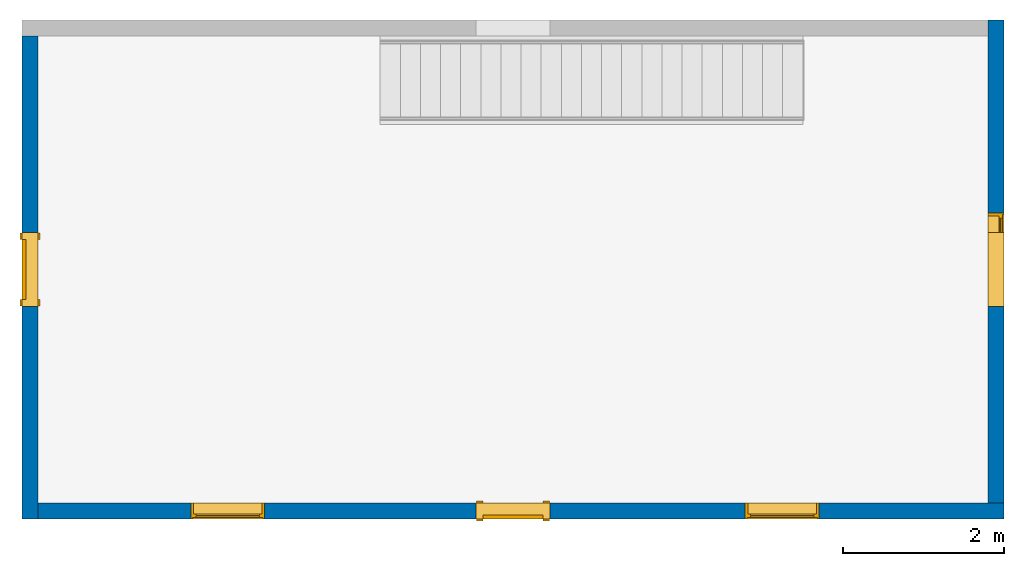
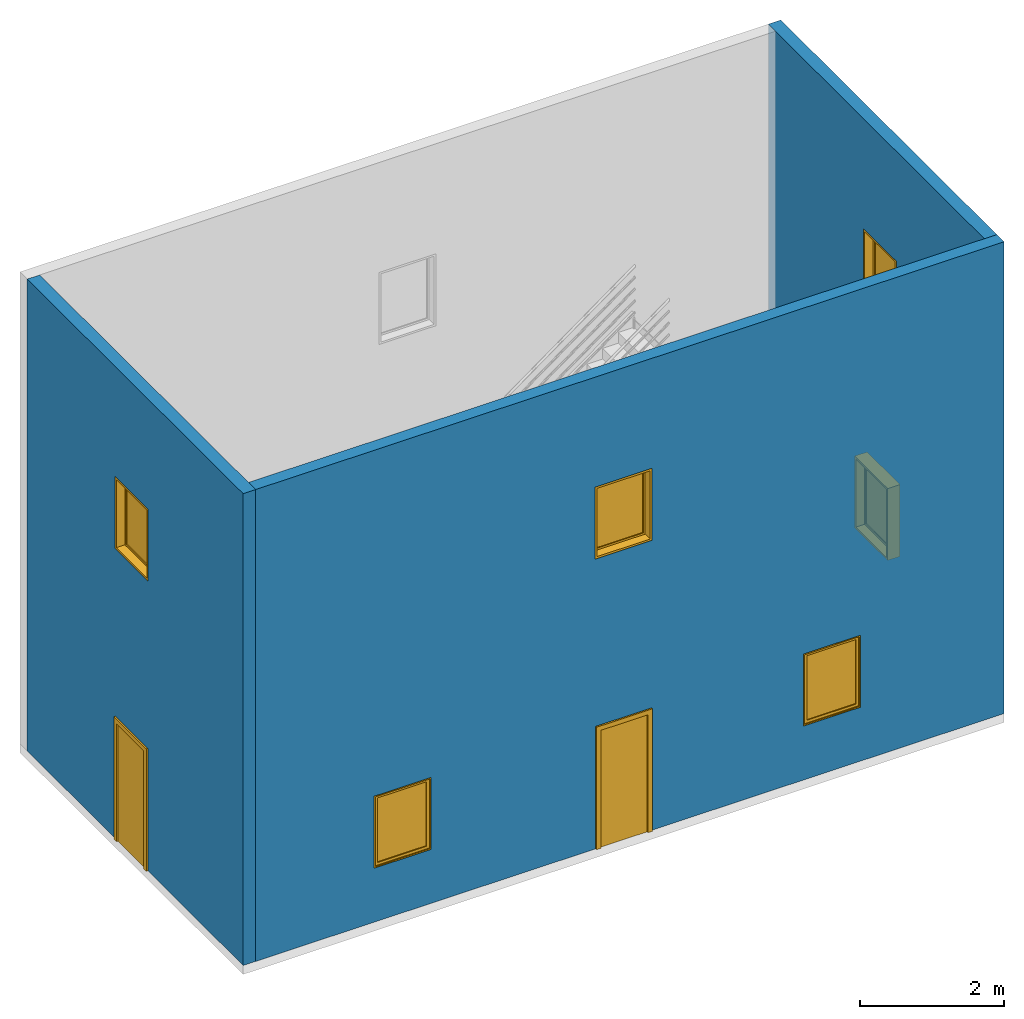
"""IFC4 building model written with IfcOpenShell, lengths in millimetres."""

import ifcopenshell
import ifcopenshell.guid

model = None  # the IFC model being written
_history = None  # IfcOwnerHistory: only IFC2X3 demands one
_inside = {}  # id of a spatial element -> (the spatial element, [elements in it])
_under = {}  # id of a project, library or spatial element -> (it, [spatial elements below it])
_declared = {}  # id of a project -> (the project, [libraries it declares])
_typed = {}  # id of a type object -> (the type object, [elements of that type])
_made_of = {}  # id of a material, layer set ... -> (it, [elements and type objects made of it])


def new_model(schema):
    """Start an empty IFC model of exactly this schema.

    Asked for "IFC4X3", IfcOpenShell would pick the latest addendum, in which some entities
    have other attributes; the version numbers below select the first issue.
    IFC2X3 requires an IfcOwnerHistory on every rooted entity: one is made here for all.
    """
    global model, _history
    if schema == "IFC4X3":
        model = ifcopenshell.file(schema_version=(4, 3, 0, 0))
    else:
        model = ifcopenshell.file(schema=schema)
    _inside.clear()
    _under.clear()
    _declared.clear()
    _typed.clear()
    _made_of.clear()
    _history = None
    if model.schema == "IFC2X3":
        org = make("IfcOrganization", Name="unknown")
        user = make(
            "IfcPersonAndOrganization",
            ThePerson=make("IfcPerson", FamilyName="unknown"),
            TheOrganization=org,
        )
        app = make(
            "IfcApplication",
            ApplicationDeveloper=org,
            Version="unknown",
            ApplicationFullName="unknown",
            ApplicationIdentifier="unknown",
        )
        _history = make(
            "IfcOwnerHistory",
            OwningUser=user,
            OwningApplication=app,
            ChangeAction="ADDED",
            CreationDate=0,
        )
    return model


def make(cls, **values):
    """One entity of the class cls with the attributes given. An attribute that is None is left unset."""
    return model.create_entity(
        cls, **{name: value for name, value in values.items() if value is not None}
    )


def entity(cls, *values):
    """Any entity or typed value of the class cls, its attributes in the order of the schema. None: left unset."""
    e = model.create_entity(cls)
    for i, value in enumerate(values):
        if value is not None:
            e[i] = value
    return e


def rooted(cls, **values):
    """An entity with a GlobalId (a new one), such as an element, a storey or a relation."""
    return make(cls, GlobalId=ifcopenshell.guid.new(), OwnerHistory=_history, **values)


def si_unit(unit_type, name, prefix=None):
    """IfcSIUnit, for example si_unit("LENGTHUNIT", "METRE", prefix="MILLI")."""
    return make("IfcSIUnit", UnitType=unit_type, Prefix=prefix, Name=name)


def converted_unit(unit_type, name, factor, base, dimensions=None, offset=None):
    """IfcConversionBasedUnit, such as the inch: factor (a typed value) times the base unit."""
    return make(
        "IfcConversionBasedUnit"
        if offset is None
        else "IfcConversionBasedUnitWithOffset",
        ConversionOffset=offset,
        Dimensions=None
        if dimensions is None
        else entity("IfcDimensionalExponents", *dimensions),
        UnitType=unit_type,
        Name=name,
        ConversionFactor=make(
            "IfcMeasureWithUnit", ValueComponent=factor, UnitComponent=base
        ),
    )


def derived_unit(unit_type, elements):
    """IfcDerivedUnit: a product of units, each with its exponent."""
    return make(
        "IfcDerivedUnit",
        Elements=[
            make("IfcDerivedUnitElement", Unit=unit, Exponent=power)
            for unit, power in elements
        ],
        UnitType=unit_type,
    )


def assignment(units):
    """IfcUnitAssignment: the units of a project."""
    return None if units is None else make("IfcUnitAssignment", Units=units)


def point(xyz):
    """IfcCartesianPoint."""
    return None if xyz is None else make("IfcCartesianPoint", Coordinates=xyz)


def direction(xyz):
    """IfcDirection."""
    return None if xyz is None else make("IfcDirection", DirectionRatios=xyz)


def frame(location, z_axis=None, x_axis=None):
    """IfcAxis2Placement3D, a coordinate frame: its origin and axes. An axis left out is left unset."""
    return make(
        "IfcAxis2Placement3D",
        Location=point(location),
        Axis=direction(z_axis),
        RefDirection=direction(x_axis),
    )


def frame_2d(location, x_axis=None):
    """IfcAxis2Placement2D, a coordinate frame in the plane: its origin and x axis."""
    return make(
        "IfcAxis2Placement2D", Location=point(location), RefDirection=direction(x_axis)
    )


def origin():
    """The frame at (0, 0, 0) with its axes left unset."""
    return frame((0.0, 0.0, 0.0))


def place(relative_to, where):
    """IfcLocalPlacement: puts the frame where relative to a parent placement (None: the world)."""
    return make(
        "IfcLocalPlacement", PlacementRelTo=relative_to, RelativePlacement=where
    )


def context(
    kind, dimensions, precision=None, world=None, true_north=None, identifier=None
):
    """IfcGeometricRepresentationContext, for example the 3D "Model" context."""
    return make(
        "IfcGeometricRepresentationContext",
        ContextIdentifier=identifier,
        ContextType=kind,
        CoordinateSpaceDimension=dimensions,
        Precision=precision,
        WorldCoordinateSystem=world,
        TrueNorth=true_north,
    )


def subcontext(parent, identifier, kind, view, scale=None):
    """IfcGeometricRepresentationSubContext, for example "Body" below "Model"."""
    return make(
        "IfcGeometricRepresentationSubContext",
        ContextIdentifier=identifier,
        ContextType=kind,
        ParentContext=parent,
        TargetScale=scale,
        TargetView=view,
    )


def project(units=None, contexts=None):
    """IfcProject with its units and contexts."""
    return rooted(
        "IfcProject",
        Name="project",
        RepresentationContexts=contexts,
        UnitsInContext=assignment(units),
    )


def spatial(cls, under=None, at=None, **own):
    """A site, building, storey or space (cls), placed at a placement, below another one or the project."""
    s = rooted(cls, ObjectPlacement=at, **own)
    if under is not None:
        _under.setdefault(under.id(), (under, []))[1].append(s)
    return s


def polyline(points):
    """IfcPolyline through the points."""
    return make("IfcPolyline", Points=[point(p) for p in points])


def point_list(points):
    """IfcCartesianPointList2D or 3D."""
    cls = (
        "IfcCartesianPointList2D" if len(points[0]) == 2 else "IfcCartesianPointList3D"
    )
    return make(cls, CoordList=points)


def profile(cls, at=None, kind="AREA", **sizes):
    """A parametric profile (cls). Its sizes go by their IFC names, for example OverallWidth=200.0."""
    return make(cls, ProfileType=kind, Position=at, **sizes)


def rectangle(**sizes):
    """IfcRectangleProfileDef."""
    return profile("IfcRectangleProfileDef", **sizes)


def outline(outer, holes=None, kind="AREA"):
    """IfcArbitraryClosedProfileDef: a profile drawn as a closed curve; with holes, ...WithVoids."""
    if holes is None:
        return make("IfcArbitraryClosedProfileDef", ProfileType=kind, OuterCurve=outer)
    return make(
        "IfcArbitraryProfileDefWithVoids",
        ProfileType=kind,
        OuterCurve=outer,
        InnerCurves=holes,
    )


def extrude(swept, where, along, depth):
    """IfcExtrudedAreaSolid: the profile swept, set in the frame where, extruded along a direction by depth."""
    return make(
        "IfcExtrudedAreaSolid",
        SweptArea=swept,
        Position=where,
        ExtrudedDirection=direction(along),
        Depth=depth,
    )


def polygons(points, faces, closed=None, point_numbers=None):
    """IfcPolygonalFaceSet: a face is its outer loop, then its inner loops; points numbered from 1."""
    made = []
    for loops in faces:
        if len(loops) == 1:
            made.append(make("IfcIndexedPolygonalFace", CoordIndex=loops[0]))
        else:
            made.append(
                make(
                    "IfcIndexedPolygonalFaceWithVoids",
                    CoordIndex=loops[0],
                    InnerCoordIndices=loops[1:],
                )
            )
    return make(
        "IfcPolygonalFaceSet",
        Coordinates=point_list(points),
        Closed=closed,
        Faces=made,
        PnIndex=point_numbers,
    )


def shape(context_of_items, identifier, shape_type, items):
    """IfcShapeRepresentation: the items that make up one representation, for example the "Body"."""
    return make(
        "IfcShapeRepresentation",
        ContextOfItems=context_of_items,
        RepresentationIdentifier=identifier,
        RepresentationType=shape_type,
        Items=items,
    )


def source(mapping_origin, context_of_items, identifier, shape_type, items):
    """IfcRepresentationMap: a shape defined once, which mapped items show again and again."""
    return make(
        "IfcRepresentationMap",
        MappingOrigin=mapping_origin,
        MappedRepresentation=shape(context_of_items, identifier, shape_type, items),
    )


def transform(
    local_origin,
    x_axis=None,
    y_axis=None,
    z_axis=None,
    scale=None,
    scale2=None,
    scale3=None,
    uniform=True,
):
    """IfcCartesianTransformationOperator3D, or its non-uniform kind. x_axis, y_axis, z_axis: its Axis1, 2, 3."""
    if uniform:
        return make(
            "IfcCartesianTransformationOperator3D",
            Axis1=direction(x_axis),
            Axis2=direction(y_axis),
            LocalOrigin=point(local_origin),
            Scale=scale,
            Axis3=direction(z_axis),
        )
    return make(
        "IfcCartesianTransformationOperator3DnonUniform",
        Axis1=direction(x_axis),
        Axis2=direction(y_axis),
        LocalOrigin=point(local_origin),
        Scale=scale,
        Axis3=direction(z_axis),
        Scale2=scale2,
        Scale3=scale3,
    )


def mapped(mapping_source, mapping_target):
    """IfcMappedItem: shows the shape of a source again, moved by a transform."""
    return make(
        "IfcMappedItem", MappingSource=mapping_source, MappingTarget=mapping_target
    )


def material(Name=None, Category=None):
    """IfcMaterial."""
    return make("IfcMaterial", Name=Name, Category=Category)


def layer(
    of_material, thickness, ventilated=None, Name=None, Category=None, Priority=None
):
    """IfcMaterialLayer: one layer of a wall or slab, of a material (None: an air gap)."""
    return make(
        "IfcMaterialLayer",
        Material=of_material,
        LayerThickness=thickness,
        IsVentilated=ventilated,
        Name=Name,
        Category=Category,
        Priority=Priority,
    )


def layer_set(layers, Name=None):
    """IfcMaterialLayerSet."""
    return make("IfcMaterialLayerSet", MaterialLayers=layers, LayerSetName=Name)


def layer_usage(for_layer_set, set_direction, sense, offset, extent=None):
    """IfcMaterialLayerSetUsage: how a layer set lies in its element."""
    return make(
        "IfcMaterialLayerSetUsage",
        ForLayerSet=for_layer_set,
        LayerSetDirection=set_direction,
        DirectionSense=sense,
        OffsetFromReferenceLine=offset,
        ReferenceExtent=extent,
    )


def constituent(of_material, Name=None, Category=None, fraction=None):
    """IfcMaterialConstituent: one of the materials an element consists of."""
    return make(
        "IfcMaterialConstituent",
        Name=Name,
        Material=of_material,
        Fraction=fraction,
        Category=Category,
    )


def constituent_set(constituents=None, Name=None):
    """IfcMaterialConstituentSet."""
    return make(
        "IfcMaterialConstituentSet", Name=Name, MaterialConstituents=constituents
    )


def made_of(thing, what):
    """Note that an element or type object is made of a material, layer set ...; save() writes the relation."""
    if what is not None:
        _made_of.setdefault(what.id(), (what, []))[1].append(thing)
    return thing


def type_object(cls, material=None, **own):
    """A type object (cls), such as IfcWallType, which elements share."""
    return made_of(rooted(cls, **own), material)


def type_shapes(of_type, sources):
    """Give a type object the sources (RepresentationMaps) that its elements show as mapped items."""
    of_type.RepresentationMaps = sources


def element(
    cls,
    number,
    at=None,
    inside=None,
    cuts=None,
    type_object=None,
    material=None,
    context=None,
    identifier="Body",
    shape_type=None,
    held_by="IfcProductDefinitionShape",
    body=None,
    shapes=None,
    **own,
):
    """One element of the class cls, such as IfcWall. Its Tag is "e" and its number.

    at: its placement. inside: the storey or other place that contains it. cuts: it is an
    opening in that element (IfcRelVoidsElement). A single representation is given by context,
    identifier, shape_type and body (its items); several are given by shapes. held_by: the class
    of the entity that holds the representations. save() writes the other relations.
    """
    e = rooted(cls, Tag="e%d" % number, ObjectPlacement=at, **own)
    if body is not None:
        shapes = [shape(context, identifier, shape_type, body)]
    if shapes is not None:
        e.Representation = make(held_by, Representations=shapes)
    if inside is not None:
        _inside.setdefault(inside.id(), (inside, []))[1].append(e)
    if cuts is not None:
        rooted(
            "IfcRelVoidsElement", RelatingBuildingElement=cuts, RelatedOpeningElement=e
        )
    if type_object is not None:
        _typed.setdefault(type_object.id(), (type_object, []))[1].append(e)
    return made_of(e, material)


def fill(opening, filler):
    """IfcRelFillsElement: the door or window that sits in an opening."""
    return rooted(
        "IfcRelFillsElement",
        RelatingOpeningElement=opening,
        RelatedBuildingElement=filler,
    )


def aggregate(whole, parts):
    """IfcRelAggregates: a whole, such as a stair, and the parts it consists of."""
    return rooted("IfcRelAggregates", RelatingObject=whole, RelatedObjects=parts)


def save(model, path):
    """Write the relations noted so far, then the file.

    IfcRelAggregates (storeys below a building ...), IfcRelContainedInSpatialStructure (elements
    in a storey), IfcRelDefinesByType, IfcRelAssociatesMaterial and IfcRelDeclares: one each for
    every whole, place, type object, material and project.
    """
    for whole, parts in _under.values():
        aggregate(whole, parts)
    for where, things in _inside.values():
        rooted(
            "IfcRelContainedInSpatialStructure",
            RelatedElements=things,
            RelatingStructure=where,
        )
    for kind, things in _typed.values():
        rooted("IfcRelDefinesByType", RelatedObjects=things, RelatingType=kind)
    for what, things in _made_of.values():
        rooted("IfcRelAssociatesMaterial", RelatedObjects=things, RelatingMaterial=what)
    for by, libraries in _declared.values():
        rooted("IfcRelDeclares", RelatingContext=by, RelatedDefinitions=libraries)
    model.write(path)


model = new_model("IFC4")

# Units and contexts
model_context = context("Model", 3, precision=0.01, world=origin(), true_north=direction((6.12303176911189e-17, 1.0)))
body_context = subcontext(model_context, "Body", "Model", "MODEL_VIEW")
ifc_project = project(units=[si_unit("LENGTHUNIT", "METRE", prefix="MILLI"), si_unit("AREAUNIT", "SQUARE_METRE"), si_unit("VOLUMEUNIT", "CUBIC_METRE"), converted_unit("PLANEANGLEUNIT", "DEGREE", entity("IfcRatioMeasure", 0.0174532925199433), si_unit("PLANEANGLEUNIT", "RADIAN"), dimensions=[0, 0, 0, 0, 0, 0, 0]), si_unit("MASSUNIT", "GRAM", prefix="KILO"), derived_unit("MASSDENSITYUNIT", [(si_unit("MASSUNIT", "GRAM", prefix="KILO"), 1), (si_unit("LENGTHUNIT", "METRE"), -3)]), si_unit("TIMEUNIT", "SECOND"), si_unit("FREQUENCYUNIT", "HERTZ"), si_unit("THERMODYNAMICTEMPERATUREUNIT", "DEGREE_CELSIUS"), derived_unit("THERMALTRANSMITTANCEUNIT", [(si_unit("MASSUNIT", "GRAM", prefix="KILO"), 1), (si_unit("THERMODYNAMICTEMPERATUREUNIT", "KELVIN"), -1), (si_unit("TIMEUNIT", "SECOND"), -3)]), derived_unit("VOLUMETRICFLOWRATEUNIT", [(si_unit("LENGTHUNIT", "METRE"), 3), (si_unit("TIMEUNIT", "SECOND"), -1)]), si_unit("ELECTRICCURRENTUNIT", "AMPERE"), si_unit("ELECTRICVOLTAGEUNIT", "VOLT"), si_unit("POWERUNIT", "WATT"), si_unit("FORCEUNIT", "NEWTON", prefix="KILO"), si_unit("ILLUMINANCEUNIT", "LUX"), si_unit("LUMINOUSFLUXUNIT", "LUMEN"), si_unit("LUMINOUSINTENSITYUNIT", "CANDELA"), derived_unit("USERDEFINED", [(si_unit("MASSUNIT", "GRAM", prefix="KILO"), -1), (si_unit("LENGTHUNIT", "METRE"), -2), (si_unit("TIMEUNIT", "SECOND"), 3), (si_unit("LUMINOUSFLUXUNIT", "LUMEN"), 1)]), derived_unit("LINEARVELOCITYUNIT", [(si_unit("LENGTHUNIT", "METRE"), 1), (si_unit("TIMEUNIT", "SECOND"), -1)]), si_unit("PRESSUREUNIT", "PASCAL"), derived_unit("USERDEFINED", [(si_unit("LENGTHUNIT", "METRE"), -2), (si_unit("MASSUNIT", "GRAM", prefix="KILO"), 1), (si_unit("TIMEUNIT", "SECOND"), -2)])], contexts=[model_context])

# Site, building, storey
site_placement = place(None, origin())
site = spatial("IfcSite", under=ifc_project, at=site_placement, CompositionType="ELEMENT")
building_placement = place(site_placement, origin())
building = spatial("IfcBuilding", under=site, at=building_placement, CompositionType="ELEMENT")
storey_1_placement = place(building_placement, origin())
storey_1 = spatial("IfcBuildingStorey", under=building, at=storey_1_placement, CompositionType="ELEMENT", Elevation=0.0)

# Wall, openings, door
ifc_material_1 = material()
ifc_layer = layer(ifc_material_1, 200.0)
ifc_layer_set = layer_set([ifc_layer], Name="Basic Wall:200mm")
ifc_layer_usage_1 = layer_usage(ifc_layer_set, "AXIS2", "NEGATIVE", 100.0)
wall_type = type_object("IfcWallType", Name="Basic Wall:200mm", PredefinedType="NOTDEFINED", material=ifc_layer_set)
wall_1_placement = place(storey_1_placement, frame((-5965.02280914634, -2119.69320336389, 0.0), z_axis=(0.0, 0.0, 1.0), x_axis=(0.0, 1.0, 0.0)))
wall_1 = element("IfcWall", 1, at=wall_1_placement, inside=storey_1, type_object=wall_type, material=ifc_layer_usage_1, Name="Basic Wall:200mm", ObjectType="Basic Wall:200mm:398", PredefinedType="NOTDEFINED", context=body_context, shape_type="Tessellation", body=[
    polygons([(6000.0, -100.0, 0.0), (3475.0, -100.0, 0.0), (3475.0, 100.0, 0.0), (6000.0, 100.0, 0.0), (3475.0, -100.0, 2000.0), (6000.0, -100.0, 8000.00000000018), (200.0, -100.0, 8000.00000000018), (0.0, -100.0, 8000.00000000018), (0.0, -100.0, -4.03399441129861e-21), (200.0, -100.0, 8.06798882259721e-21), (2725.0, -100.0, -8.06798882259721e-21), (2725.0, -100.0, 2000.0), (3557.5, -100.0, 4915.0), (2642.5, -100.0, 4915.0), (2642.5, -100.0, 6135.0), (3557.5, -100.0, 6135.0), (3475.0, 100.0, 2000.0), (2725.0, 100.0, 2000.0), (2725.0, 100.0, -8.06798882259721e-21), (0.0, 100.0, 0.0), (0.0, 100.0, 8000.00000000018), (6000.0, 100.0, 8000.00000000018), (3557.5, 100.0, 4915.0), (3557.5, 100.0, 6135.0), (2642.5, 100.0, 6135.0), (2642.5, 100.0, 4915.0)], [[[1, 2, 3, 4]], [[1, 4, 22, 6]], [[17, 3, 2, 5]], [[18, 19, 20, 21, 22, 4, 3, 17], [26, 23, 24, 25]], [[5, 2, 1, 6, 7, 8, 9, 10, 11, 12], [13, 14, 15, 16]], [[18, 17, 5, 12]], [[19, 18, 12, 11]], [[10, 9, 20, 19, 11]], [[21, 20, 9, 8]], [[26, 25, 15, 14]], [[23, 26, 14, 13]], [[7, 6, 22, 21, 8]], [[25, 24, 16, 15]], [[24, 23, 13, 16]]], closed=True),
])
opening_1_placement = place(wall_1_placement, frame((2725.0, -100.0, 0.0)))
opening_1 = element("IfcOpeningElement", 2, at=opening_1_placement, cuts=wall_1, ObjectType="Opening", PredefinedType="OPENING", context=body_context, shape_type="SweptSolid", body=[
    extrude(rectangle(XDim=750.0, YDim=2000.0, at=frame_2d((1000.0, 375.0), x_axis=(0.0, 1.0))), frame((0.0, 0.0, 0.0), z_axis=(0.0, 1.0, 0.0), x_axis=(0.0, 0.0, 1.0)), (0.0, 0.0, 1.0), 200.0),
])
opening_2_placement = place(wall_1_placement, frame((3557.5, 100.0, 4915.0)))
opening_2 = element("IfcOpeningElement", 3, at=opening_2_placement, cuts=wall_1, ObjectType="Opening", PredefinedType="OPENING", context=body_context, shape_type="SweptSolid", body=[
    extrude(rectangle(XDim=1220.0, YDim=914.999999999999, at=frame_2d((609.999999999999, 457.5), x_axis=(1.0, 0.0))), frame((0.0, 0.0, 0.0), z_axis=(0.0, -1.0, 0.0), x_axis=(0.0, 0.0, 1.0)), (0.0, 0.0, 1.0), 200.0),
])
ifc_material_2 = material()
ifc_constituent_1 = constituent(ifc_material_2, Category="Materials")
ifc_material_3 = material()
ifc_constituent_2 = constituent(ifc_material_3, Category="Materials")
ifc_constituent_set_1 = constituent_set(constituents=[ifc_constituent_1, ifc_constituent_2])
ifc_constituent_3 = constituent(ifc_material_2, Category="Materials")
ifc_constituent_4 = constituent(ifc_material_3, Category="Materials")
ifc_constituent_set_2 = constituent_set(constituents=[ifc_constituent_3, ifc_constituent_4])
door_type = type_object("IfcDoorType", Name="750 x 2000mm", OperationType="SINGLE_SWING_RIGHT", ParameterTakesPrecedence=False, PredefinedType="DOOR", material=ifc_constituent_set_2)
shared_shape_1 = source(origin(), body_context, "Body", "SweptSolid", [
    extrude(outline(polyline([(-451.0, -1057.0), (451.0, -1057.0), (451.0, 1019.0), (375.0, 1019.0), (375.0, -981.0), (-375.0, -981.0), (-375.0, 1019.0), (-451.0, 1019.0), (-451.0, -1057.0)])), frame((375.0, 200.0, 1019.0), z_axis=(0.0, 1.0, 0.0), x_axis=(1.0, 0.0, 0.0)), (0.0, 0.0, 1.0), 24.9999999999945),
    extrude(outline(polyline([(-1057.0, -451.0), (1019.0, -451.0), (1019.0, -375.0), (-981.0, -375.0), (-981.0, 375.0), (1019.0, 375.0), (1019.0, 451.0), (-1057.0, 451.0), (-1057.0, -451.0)])), frame((375.0, -25.0, 1019.0), z_axis=(0.0, 1.0, 0.0), x_axis=(0.0, 0.0, -1.0)), (0.0, 0.0, 1.0), 25.0000000000056),
    extrude(rectangle(XDim=51.0, YDim=750.0, at=frame_2d((-5.32907051820075e-15, 0.0), x_axis=(1.0, 0.0))), frame((375.0, 174.499999999999, 0.0), z_axis=(0.0, 0.0, 1.0), x_axis=(0.0, 1.0, 0.0)), (0.0, 0.0, 1.0), 2000.0),
])
type_shapes(door_type, [shared_shape_1])
door_1_placement = place(opening_1_placement, origin())
door_1 = element("IfcDoor", 4, at=door_1_placement, inside=storey_1, type_object=door_type, material=ifc_constituent_set_1, ObjectType="750 x 2000mm", OperationType="SINGLE_SWING_RIGHT", OverallHeight=2000.0, OverallWidth=750.0, PredefinedType="DOOR", context=body_context, shape_type="MappedRepresentation", body=[
    mapped(shared_shape_1, transform((0.0, 0.0, 0.0), scale=1.0)),
])
fill(opening_1, door_1)

# Storey
storey_2_placement = place(building_placement, frame((0.0, 0.0, 4000.0)))
storey_2 = spatial("IfcBuildingStorey", under=building, at=storey_2_placement, CompositionType="ELEMENT", Elevation=4000.0)

# Window
ifc_material_4 = material()
ifc_constituent_5 = constituent(ifc_material_4, Category="Materials")
ifc_material_5 = material()
ifc_constituent_6 = constituent(ifc_material_5, Category="Materials")
ifc_constituent_set_3 = constituent_set(constituents=[ifc_constituent_5, ifc_constituent_6])
ifc_constituent_7 = constituent(ifc_material_4, Category="Materials")
ifc_constituent_8 = constituent(ifc_material_5, Category="Materials")
ifc_constituent_set_4 = constituent_set(constituents=[ifc_constituent_7, ifc_constituent_8])
window_type = type_object("IfcWindowType", Name="0915 x 1220mm", ParameterTakesPrecedence=False, PartitioningType="NOTDEFINED", PredefinedType="WINDOW", material=ifc_constituent_set_4)
shared_shape_2 = source(origin(), body_context, "Body", "SweptSolid", [
    extrude(rectangle(XDim=12.0, YDim=788.999999999997, at=frame_2d((8.43769498715119e-15, 0.0), x_axis=(1.0, 0.0))), frame((457.500000000006, 159.0, 63.0), z_axis=(0.0, 0.0, 1.0), x_axis=(0.0, -1.0, 0.0)), (0.0, 0.0, 1.0), 1094.00000000001),
    extrude(outline(polyline([(-438.5, -591.0), (438.5, -591.0), (438.5, 591.0), (-438.5, 591.0), (-438.5, -591.0)]), holes=[polyline([(-394.5, -547.0), (-394.5, 547.0), (394.499999999998, 547.0), (394.499999999998, -547.0), (-394.5, -547.0)])]), frame((457.500000000007, 137.0, 610.0), z_axis=(0.0, 1.0, 0.0), x_axis=(1.0, 0.0, 0.0)), (0.0, 0.0, 1.0), 44.0000000000274),
    extrude(outline(polyline([(-457.5, -610.0), (457.5, -610.0), (457.5, 610.0), (-457.5, 610.0), (-457.5, -610.0)]), holes=[polyline([(-438.500000000001, -591.0), (-438.500000000001, 591.0), (438.499999999999, 591.0), (438.499999999999, -591.0), (-438.500000000001, -591.0)])]), frame((457.500000000008, 137.0, 610.0), z_axis=(0.0, 1.0, 0.0), x_axis=(1.0, 0.0, 0.0)), (0.0, 0.0, 1.0), 63.0000000000274),
    extrude(outline(polyline([(-457.5, -610.0), (457.5, -610.0), (457.5, 610.0), (-457.5, 610.0), (-457.5, -610.0)]), holes=[polyline([(-425.5, -578.0), (-425.5, 578.0), (425.5, 578.0), (425.5, -578.0), (-425.5, -578.0)])]), frame((457.500000000008, 0.0, 610.0), z_axis=(0.0, 1.0, 0.0), x_axis=(1.0, 0.0, 0.0)), (0.0, 0.0, 1.0), 136.999999999973),
])
type_shapes(window_type, [shared_shape_2])
window_1_placement = place(opening_2_placement, frame((0.0, 0.0, 0.0), z_axis=(0.0, 0.0, 1.0), x_axis=(-1.0, 0.0, 0.0)))
window_1 = element("IfcWindow", 5, at=window_1_placement, inside=storey_2, type_object=window_type, material=ifc_constituent_set_3, ObjectType="0915 x 1220mm", OverallHeight=1220.0, OverallWidth=914.999999999999, PartitioningType="NOTDEFINED", PredefinedType="WINDOW", context=body_context, shape_type="MappedRepresentation", body=[
    mapped(shared_shape_2, transform((0.0, 0.0, 0.0), scale=1.0)),
])

fill(opening_2, window_1)

# Wall, openings, door, windows
ifc_layer_usage_2 = layer_usage(ifc_layer_set, "AXIS2", "NEGATIVE", 100.0)
wall_2_placement = place(storey_1_placement, frame((6134.97719085366, -2019.69320336389, 0.0), z_axis=(0.0, 0.0, 1.0), x_axis=(-1.0, 0.0, 0.0)))
wall_2 = element("IfcWall", 6, at=wall_2_placement, inside=storey_1, type_object=wall_type, material=ifc_layer_usage_2, Name="Basic Wall:200mm", ObjectType="Basic Wall:200mm:398", PredefinedType="NOTDEFINED", context=body_context, shape_type="Tessellation", body=[
    polygons([(12000.0, -100.0, 0.0), (6475.0, -100.0, 0.0), (6475.0, 100.0, 0.0), (12000.0, 100.0, 0.0), (6475.0, -100.0, 2000.0), (12000.0, -100.0, 8000.00000000018), (199.999999999999, -100.0, 8000.00000000018), (1.08286712929839e-12, -100.0, 8000.00000000018), (0.0, -100.0, 0.0), (200.0, -100.0, 2.0169972056493e-21), (5725.0, -100.0, 4.03399441129861e-21), (5725.0, -100.0, 2000.0), (6557.5, -100.0, 4915.0), (5642.5, -100.0, 4915.0), (5642.5, -100.0, 6135.0), (6557.5, -100.0, 6135.0), (2300.0, -100.0, 915.000000000005), (2300.0, -100.0, 2135.0), (3215.0, -100.0, 2135.0), (3215.0, -100.0, 915.000000000005), (9185.0, -100.0, 915.000000000005), (9185.0, -100.0, 2135.0), (10100.0, -100.0, 2135.0), (10100.0, -100.0, 915.000000000005), (6475.0, 100.0, 2000.0), (5725.0, 100.0, 2000.0), (5725.0, 100.0, -4.03399441129861e-21), (1.08286712929839e-12, 100.0, 2.0169972056493e-21), (0.0, 100.0, 8000.00000000018), (12000.0, 100.0, 8000.00000000018), (6557.5, 100.0, 4915.0), (6557.5, 100.0, 6135.0), (5642.5, 100.0, 6135.0), (5642.5, 100.0, 4915.0), (2300.0, 100.0, 915.000000000005), (3215.0, 100.0, 915.000000000005), (3215.0, 100.0, 2135.0), (2300.0, 100.0, 2135.0), (9185.0, 100.0, 915.000000000005), (10100.0, 100.0, 915.000000000005), (10100.0, 100.0, 2135.0), (9185.0, 100.0, 2135.0)], [[[1, 2, 3, 4]], [[22, 21, 39, 42]], [[1, 4, 30, 6]], [[25, 3, 2, 5]], [[28, 29, 30, 4, 3, 25, 26, 27], [36, 37, 38, 35], [34, 31, 32, 33], [42, 39, 40, 41]], [[6, 7, 8, 9, 10, 11, 12, 5, 2, 1], [23, 24, 21, 22], [13, 14, 15, 16], [19, 20, 17, 18]], [[18, 17, 35, 38]], [[19, 18, 38, 37]], [[10, 9, 28, 27, 11]], [[29, 28, 9, 8]], [[20, 19, 37, 36]], [[17, 20, 36, 35]], [[27, 26, 12, 11]], [[26, 25, 5, 12]], [[7, 6, 30, 29, 8]], [[34, 33, 15, 14]], [[31, 34, 14, 13]], [[33, 32, 16, 15]], [[32, 31, 13, 16]], [[21, 24, 40, 39]], [[24, 23, 41, 40]], [[23, 22, 42, 41]]], closed=True),
])
opening_3_placement = place(wall_2_placement, frame((5725.0, -100.0, 0.0)))
opening_3 = element("IfcOpeningElement", 7, at=opening_3_placement, cuts=wall_2, ObjectType="Opening", PredefinedType="OPENING", context=body_context, shape_type="SweptSolid", body=[
    extrude(rectangle(XDim=750.0, YDim=2000.0, at=frame_2d((1000.0, 375.0), x_axis=(0.0, 1.0))), frame((0.0, 0.0, 0.0), z_axis=(0.0, 1.0, 0.0), x_axis=(0.0, 0.0, 1.0)), (0.0, 0.0, 1.0), 200.0),
])
opening_4_placement = place(wall_2_placement, frame((6557.5, 100.0, 4915.0)))
opening_4 = element("IfcOpeningElement", 8, at=opening_4_placement, cuts=wall_2, ObjectType="Opening", PredefinedType="OPENING", context=body_context, shape_type="SweptSolid", body=[
    extrude(rectangle(XDim=1220.0, YDim=914.999999999999, at=frame_2d((609.999999999999, 457.5), x_axis=(1.0, 0.0))), frame((0.0, 0.0, 0.0), z_axis=(0.0, -1.0, 0.0), x_axis=(0.0, 0.0, 1.0)), (0.0, 0.0, 1.0), 200.0),
])
opening_5_placement = place(wall_2_placement, frame((2300.0, -100.0, 915.0)))
opening_5 = element("IfcOpeningElement", 9, at=opening_5_placement, cuts=wall_2, ObjectType="Opening", PredefinedType="OPENING", context=body_context, shape_type="SweptSolid", body=[
    extrude(rectangle(XDim=1220.0, YDim=914.999999999999, at=frame_2d((609.999999999999, 457.5), x_axis=(1.0, 0.0))), frame((0.0, 0.0, 0.0), z_axis=(0.0, 1.0, 0.0), x_axis=(0.0, 0.0, 1.0)), (0.0, 0.0, 1.0), 200.0),
])
opening_6_placement = place(wall_2_placement, frame((9185.0, -100.0, 915.0)))
opening_6 = element("IfcOpeningElement", 10, at=opening_6_placement, cuts=wall_2, ObjectType="Opening", PredefinedType="OPENING", context=body_context, shape_type="SweptSolid", body=[
    extrude(rectangle(XDim=1220.0, YDim=914.999999999999, at=frame_2d((609.999999999999, 457.5), x_axis=(1.0, 0.0))), frame((0.0, 0.0, 0.0), z_axis=(0.0, 1.0, 0.0), x_axis=(0.0, 0.0, 1.0)), (0.0, 0.0, 1.0), 200.0),
])
ifc_constituent_9 = constituent(ifc_material_2, Category="Materials")
ifc_constituent_10 = constituent(ifc_material_3, Category="Materials")
ifc_constituent_set_5 = constituent_set(constituents=[ifc_constituent_9, ifc_constituent_10])
door_2_placement = place(opening_3_placement, origin())
door_2 = element("IfcDoor", 11, at=door_2_placement, inside=storey_1, type_object=door_type, material=ifc_constituent_set_5, ObjectType="750 x 2000mm", OperationType="SINGLE_SWING_RIGHT", OverallHeight=2000.0, OverallWidth=750.0, PredefinedType="DOOR", context=body_context, shape_type="MappedRepresentation", body=[
    mapped(shared_shape_1, transform((0.0, 0.0, 0.0), scale=1.0)),
])
fill(opening_3, door_2)
ifc_constituent_11 = constituent(ifc_material_4, Category="Materials")
ifc_constituent_12 = constituent(ifc_material_5, Category="Materials")
ifc_constituent_set_6 = constituent_set(constituents=[ifc_constituent_11, ifc_constituent_12])
window_2_placement = place(opening_4_placement, frame((0.0, 0.0, 0.0), z_axis=(0.0, 0.0, 1.0), x_axis=(-1.0, 0.0, 0.0)))
window_2 = element("IfcWindow", 12, at=window_2_placement, inside=storey_2, type_object=window_type, material=ifc_constituent_set_6, ObjectType="0915 x 1220mm", OverallHeight=1220.0, OverallWidth=914.999999999999, PartitioningType="NOTDEFINED", PredefinedType="WINDOW", context=body_context, shape_type="MappedRepresentation", body=[
    mapped(shared_shape_2, transform((0.0, 0.0, 0.0), scale=1.0)),
])
fill(opening_4, window_2)
ifc_constituent_13 = constituent(ifc_material_4, Category="Materials")
ifc_constituent_14 = constituent(ifc_material_5, Category="Materials")
ifc_constituent_set_7 = constituent_set(constituents=[ifc_constituent_13, ifc_constituent_14])
window_3_placement = place(opening_5_placement, origin())
window_3 = element("IfcWindow", 13, at=window_3_placement, inside=storey_1, type_object=window_type, material=ifc_constituent_set_7, ObjectType="0915 x 1220mm", OverallHeight=1220.0, OverallWidth=914.999999999999, PartitioningType="NOTDEFINED", PredefinedType="WINDOW", context=body_context, shape_type="MappedRepresentation", body=[
    mapped(shared_shape_2, transform((0.0, 0.0, 0.0), scale=1.0)),
])
fill(opening_5, window_3)
ifc_constituent_15 = constituent(ifc_material_4, Category="Materials")
ifc_constituent_16 = constituent(ifc_material_5, Category="Materials")
ifc_constituent_set_8 = constituent_set(constituents=[ifc_constituent_15, ifc_constituent_16])
window_4_placement = place(opening_6_placement, origin())
window_4 = element("IfcWindow", 14, at=window_4_placement, inside=storey_1, type_object=window_type, material=ifc_constituent_set_8, ObjectType="0915 x 1220mm", OverallHeight=1220.0, OverallWidth=914.999999999999, PartitioningType="NOTDEFINED", PredefinedType="WINDOW", context=body_context, shape_type="MappedRepresentation", body=[
    mapped(shared_shape_2, transform((0.0, 0.0, 0.0), scale=1.0)),
])
fill(opening_6, window_4)

# Wall, openings, windows
ifc_layer_usage_3 = layer_usage(ifc_layer_set, "AXIS2", "NEGATIVE", 100.0)
wall_3_placement = place(storey_1_placement, frame((6034.97719085366, 4080.30679663611, 0.0), z_axis=(0.0, 0.0, 1.0), x_axis=(0.0, -1.0, 0.0)))
wall_3 = element("IfcWall", 15, at=wall_3_placement, inside=storey_1, type_object=wall_type, material=ifc_layer_usage_3, Name="Basic Wall:200mm", ObjectType="Basic Wall:200mm:398", PredefinedType="NOTDEFINED", context=body_context, shape_type="Tessellation", body=[
    polygons([(0.0, -100.0, -4.03399441129861e-21), (200.0, -100.0, 8.06798882259721e-21), (6000.0, -100.0, 0.0), (6000.0, -100.0, 8000.00000000018), (200.0, -100.0, 8000.00000000018), (0.0, -100.0, 8000.00000000018), (2642.5, -100.0, 4915.0), (2642.5, -100.0, 6135.0), (3557.5, -100.0, 6135.0), (3557.5, -100.0, 4915.0), (2400.0, -100.0, 915.000000000005), (2400.0, -100.0, 2135.0), (3315.0, -100.0, 2135.0), (3315.0, -100.0, 915.000000000005), (0.0, 100.0, 0.0), (0.0, 100.0, 8000.00000000018), (6000.0, 100.0, 8000.00000000018), (6000.0, 100.0, -4.03399441129861e-21), (2642.5, 100.0, 4915.0), (3557.5, 100.0, 4915.0), (3557.5, 100.0, 6135.0), (2642.5, 100.0, 6135.0), (2400.0, 100.0, 915.000000000005), (3315.0, 100.0, 915.000000000005), (3315.0, 100.0, 2135.0), (2400.0, 100.0, 2135.0)], [[[3, 4, 5, 6, 1, 2], [10, 7, 8, 9], [13, 14, 11, 12]], [[12, 11, 23, 26]], [[13, 12, 26, 25]], [[2, 1, 15, 18, 3]], [[16, 15, 1, 6]], [[11, 14, 24, 23]], [[14, 13, 25, 24]], [[7, 10, 20, 19]], [[8, 7, 19, 22]], [[9, 8, 22, 21]], [[5, 4, 17, 16, 6]], [[10, 9, 21, 20]], [[3, 18, 17, 4]], [[16, 17, 18, 15], [19, 20, 21, 22], [26, 23, 24, 25]]], closed=True),
])
opening_7_placement = place(wall_3_placement, frame((2642.5, -100.0, 4915.0)))
opening_7 = element("IfcOpeningElement", 16, at=opening_7_placement, cuts=wall_3, ObjectType="Opening", PredefinedType="OPENING", context=body_context, shape_type="SweptSolid", body=[
    extrude(rectangle(XDim=1220.0, YDim=914.999999999999, at=frame_2d((609.999999999999, 457.5), x_axis=(1.0, 0.0))), frame((0.0, 0.0, 0.0), z_axis=(0.0, 1.0, 0.0), x_axis=(0.0, 0.0, 1.0)), (0.0, 0.0, 1.0), 200.0),
])
opening_8_placement = place(wall_3_placement, frame((2400.0, -100.0, 915.0)))
opening_8 = element("IfcOpeningElement", 17, at=opening_8_placement, cuts=wall_3, ObjectType="Opening", PredefinedType="OPENING", context=body_context, shape_type="SweptSolid", body=[
    extrude(rectangle(XDim=1220.0, YDim=914.999999999999, at=frame_2d((609.999999999999, 457.5), x_axis=(1.0, 0.0))), frame((0.0, 0.0, 0.0), z_axis=(0.0, 1.0, 0.0), x_axis=(0.0, 0.0, 1.0)), (0.0, 0.0, 1.0), 200.0),
])
ifc_constituent_17 = constituent(ifc_material_4, Category="Materials")
ifc_constituent_18 = constituent(ifc_material_5, Category="Materials")
ifc_constituent_set_9 = constituent_set(constituents=[ifc_constituent_17, ifc_constituent_18])
window_5_placement = place(opening_7_placement, origin())
window_5 = element("IfcWindow", 18, at=window_5_placement, inside=storey_2, type_object=window_type, material=ifc_constituent_set_9, ObjectType="0915 x 1220mm", OverallHeight=1220.0, OverallWidth=914.999999999999, PartitioningType="NOTDEFINED", PredefinedType="WINDOW", context=body_context, shape_type="MappedRepresentation", body=[
    mapped(shared_shape_2, transform((0.0, 0.0, 0.0), scale=1.0)),
])
fill(opening_7, window_5)
ifc_constituent_19 = constituent(ifc_material_4, Category="Materials")
ifc_constituent_20 = constituent(ifc_material_5, Category="Materials")
ifc_constituent_set_10 = constituent_set(constituents=[ifc_constituent_19, ifc_constituent_20])
window_6_placement = place(opening_8_placement, origin())
window_6 = element("IfcWindow", 19, at=window_6_placement, inside=storey_1, type_object=window_type, material=ifc_constituent_set_10, ObjectType="0915 x 1220mm", OverallHeight=1220.0, OverallWidth=914.999999999999, PartitioningType="NOTDEFINED", PredefinedType="WINDOW", context=body_context, shape_type="MappedRepresentation", body=[
    mapped(shared_shape_2, transform((0.0, 0.0, 0.0), scale=1.0)),
])
fill(opening_8, window_6)

save(model, "model.ifc")
